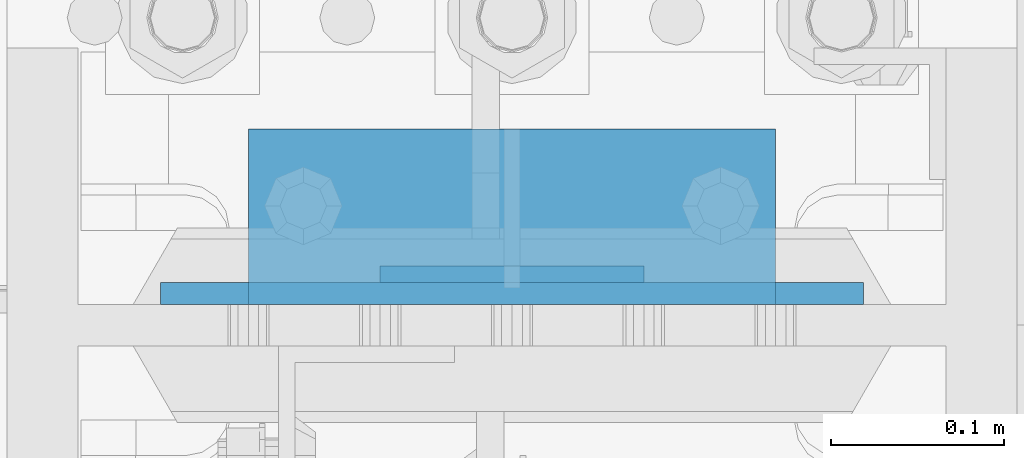
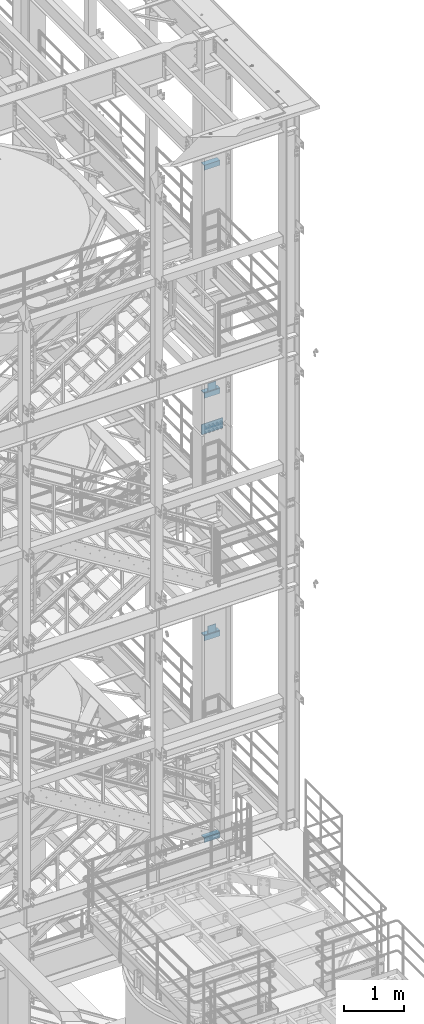
# One storey, part 1220 of 1876: 9 beams, 4 elements without a shape of their own.
"""IFC2X3 building model written with IfcOpenShell, lengths in millimetres."""

from ifc_helpers import new_model, si_unit, frame, origin_with_axes, place, context, subcontext, project, spatial, faceted_brep, material, type_object, element, aggregate, save


model = new_model("IFC2X3")

# Units and contexts
model_context = context("Model", 3, precision=1e-05, world=origin_with_axes())
body_context = subcontext(model_context, "Body", "Model", "MODEL_VIEW")
ifc_project = project(units=[si_unit("LENGTHUNIT", "METRE", prefix="MILLI"), si_unit("AREAUNIT", "SQUARE_METRE"), si_unit("VOLUMEUNIT", "CUBIC_METRE"), si_unit("MASSUNIT", "GRAM", prefix="KILO"), si_unit("TIMEUNIT", "SECOND"), si_unit("PLANEANGLEUNIT", "RADIAN"), si_unit("SOLIDANGLEUNIT", "STERADIAN"), si_unit("THERMODYNAMICTEMPERATUREUNIT", "DEGREE_CELSIUS"), si_unit("LUMINOUSINTENSITYUNIT", "LUMEN")], contexts=[model_context])

# Site, building, storey
site_placement = place(None, origin_with_axes())
site = spatial("IfcSite", under=ifc_project, at=site_placement, CompositionType="ELEMENT")
building_placement = place(site_placement, origin_with_axes())
building = spatial("IfcBuilding", under=site, at=building_placement, Name="Undefined", CompositionType="ELEMENT")
storey_placement = place(building_placement, origin_with_axes())
storey = spatial("IfcBuildingStorey", under=building, at=storey_placement, Name="Undefined", CompositionType="ELEMENT", Elevation=0.0)

# Assembly, beam
assembly_1_placement = place(storey_placement, origin_with_axes())
assembly_1 = element("IfcElementAssembly", 1, at=assembly_1_placement, inside=storey, Name="BEAM", AssemblyPlace="NOTDEFINED", PredefinedType="RIGID_FRAME")
ifc_material_1 = material(Name="STEEL/A36")
beam_type_1 = type_object("IfcBeamType", PredefinedType="NOTDEFINED")
beam_1_placement = place(assembly_1_placement, frame((7696.2, -4542.63125, 15335.25), z_axis=(0.0, 0.0, 1.0), x_axis=(-1.0, 0.0, 0.0)))
beam_1 = element("IfcBeam", 2, at=beam_1_placement, type_object=beam_type_1, material=ifc_material_1, Name="PLATE", context=body_context, shape_type="Brep", body=[
    faceted_brep([(0.0, 4.76249999999982, -76.1999999999998), (3.63797880709171e-12, 4.76249999999982, 76.1999969482422), (152.399993896484, 4.76250000000073, 76.1999969482422), (152.4, 4.76249999999982, -76.1999999999998), (3.63797880709171e-12, -4.76249999999982, 76.1999969482422), (152.399993896484, -4.76250000000073, 76.1999969482422), (0.0, -4.76249999999982, -76.1999999999998), (152.4, -4.76249999999982, -76.1999999999998)], [[[0, 1, 2, 3]], [[4, 5, 2, 1]], [[4, 6, 7, 5]], [[6, 0, 3, 7]], [[5, 7, 3, 2]], [[6, 4, 1, 0]]]),
])

assembly_2_placement = place(storey_placement, origin_with_axes())
assembly_2 = element("IfcElementAssembly", 3, at=assembly_2_placement, inside=storey, Name="BEAM", AssemblyPlace="NOTDEFINED", PredefinedType="RIGID_FRAME")
beam_2_placement = place(assembly_2_placement, frame((7696.2, -4542.63125, 10420.35), z_axis=(0.0, 0.0, 1.0), x_axis=(-1.0, 0.0, 0.0)))
beam_2 = element("IfcBeam", 4, at=beam_2_placement, type_object=beam_type_1, material=ifc_material_1, Name="PLATE", context=body_context, shape_type="Brep", body=[
    faceted_brep([(0.0, 4.76249999999982, -76.1999999999998), (3.63797880709171e-12, 4.76249999999982, 76.1999969482422), (152.399993896484, 4.76250000000073, 76.1999969482422), (152.4, 4.76249999999982, -76.1999999999998), (3.63797880709171e-12, -4.76249999999982, 76.1999969482422), (152.399993896484, -4.76250000000073, 76.1999969482422), (0.0, -4.76249999999982, -76.1999999999998), (152.4, -4.76249999999982, -76.1999999999998)], [[[0, 1, 2, 3]], [[4, 5, 2, 1]], [[4, 6, 7, 5]], [[6, 0, 3, 7]], [[5, 7, 3, 2]], [[6, 4, 1, 0]]]),
])

# Beam
beam_type_2 = type_object("IfcBeamType", PredefinedType="NOTDEFINED")
beam_3_placement = place(assembly_1_placement, frame((7467.6, -4502.94375, 15254.2875), z_axis=(0.0, 1.0, 0.0), x_axis=(1.0, 0.0, 0.0)))
beam_3 = element("IfcBeam", 5, at=beam_3_placement, type_object=beam_type_2, material=ifc_material_1, Name="PLATE", context=body_context, shape_type="Brep", body=[
    faceted_brep([(0.0, 4.76250000000073, -44.4499999999998), (0.0, 4.76250000000073, 44.4499999999998), (304.799999999999, 4.76250000000073, 44.4499999999998), (304.799999999999, 4.76250000000073, -44.4499999999998), (0.0, -4.76250000000073, 44.4499999999998), (304.799999999999, -4.76250000000073, 44.4499999999998), (0.0, -4.76250000000073, -44.4499999999998), (304.799999999999, -4.76250000000073, -44.4499999999998)], [[[0, 1, 2, 3]], [[1, 4, 5, 2]], [[4, 6, 7, 5]], [[6, 0, 3, 7]], [[5, 7, 3, 2]], [[6, 4, 1, 0]]]),
])

aggregate(assembly_1, [beam_1, beam_3])

beam_4_placement = place(assembly_2_placement, frame((7467.6, -4502.94375, 10339.3875), z_axis=(0.0, 1.0, 0.0), x_axis=(1.0, 0.0, 0.0)))
beam_4 = element("IfcBeam", 6, at=beam_4_placement, type_object=beam_type_2, material=ifc_material_1, Name="PLATE", context=body_context, shape_type="Brep", body=[
    faceted_brep([(0.0, 4.76250000000073, -44.4499999999998), (0.0, 4.76250000000073, 44.4499999999998), (304.799999999999, 4.76250000000073, 44.4499999999998), (304.799999999999, 4.76250000000073, -44.4499999999998), (0.0, -4.76250000000073, 44.4499999999998), (304.799999999999, -4.76250000000073, 44.4499999999998), (0.0, -4.76250000000073, -44.4499999999998), (304.799999999999, -4.76250000000073, -44.4499999999998)], [[[0, 1, 2, 3]], [[1, 4, 5, 2]], [[4, 6, 7, 5]], [[6, 0, 3, 7]], [[5, 7, 3, 2]], [[6, 4, 1, 0]]]),
])

aggregate(assembly_2, [beam_2, beam_4])

# Assembly, beams
assembly_3_placement = place(storey_placement, origin_with_axes())
assembly_3 = element("IfcElementAssembly", 7, at=assembly_3_placement, inside=storey, Name="COLUMN", AssemblyPlace="NOTDEFINED", PredefinedType="RIGID_FRAME")
beam_type_3 = type_object("IfcBeamType", Name="L4X4X3/8", PredefinedType="NOTDEFINED")
beam_5_placement = place(assembly_3_placement, frame((7772.4, -4509.29375, 19821.525), z_axis=(0.0, 1.0, 0.0), x_axis=(-1.0, 0.0, 0.0)))
beam_5 = element("IfcBeam", 8, at=beam_5_placement, type_object=beam_type_3, material=ifc_material_1, Name="ANGLE", ObjectType="L4X4X3/8", context=body_context, shape_type="Brep", body=[
    faceted_brep([(0.0, 50.7999999999993, -50.8000000000002), (0.0, 50.7999999999993, 50.8000000000002), (304.799999999999, 50.7999999999993, 50.8000000000002), (304.799999999999, 50.7999999999993, -50.8000000000002), (0.0, 41.2750000000015, 50.8000000000002), (304.799999999999, 41.2750000000015, 50.8000000000002), (0.0, 41.2750000000015, -41.2749999999996), (304.799999999999, 41.2750000000015, -41.2749999999996), (0.0, -50.7999999999993, -41.2749999999996), (304.799999999999, -50.7999999999993, -41.2749999999996), (0.0, -50.7999999999993, -50.8000000000002), (304.799999999999, -50.7999999999993, -50.8000000000002)], [[[0, 1, 2, 3]], [[1, 4, 5, 2]], [[4, 6, 7, 5]], [[6, 8, 9, 7]], [[8, 10, 11, 9]], [[10, 0, 3, 11]], [[5, 7, 9, 11, 3, 2]], [[10, 8, 6, 4, 1, 0]]]),
])
beam_6_placement = place(assembly_3_placement, frame((7772.4, -4509.29375, 15198.725), z_axis=(0.0, 1.0, 0.0), x_axis=(-1.0, 0.0, 0.0)))
beam_6 = element("IfcBeam", 9, at=beam_6_placement, type_object=beam_type_3, material=ifc_material_1, Name="ANGLE", ObjectType="L4X4X3/8", context=body_context, shape_type="Brep", body=[
    faceted_brep([(0.0, 50.7999999999993, -50.8000000000002), (0.0, 50.7999999999993, 50.8000000000002), (304.799999999999, 50.7999999999993, 50.8000000000002), (304.799999999999, 50.7999999999993, -50.8000000000002), (0.0, 41.2750000000015, 50.8000000000002), (304.799999999999, 41.2750000000015, 50.8000000000002), (0.0, 41.2750000000015, -41.2749999999996), (304.799999999999, 41.2750000000015, -41.2749999999996), (0.0, -50.7999999999993, -41.2749999999996), (304.799999999999, -50.7999999999993, -41.2749999999996), (0.0, -50.7999999999993, -50.8000000000002), (304.799999999999, -50.7999999999993, -50.8000000000002)], [[[0, 1, 2, 3]], [[1, 4, 5, 2]], [[4, 6, 7, 5]], [[6, 8, 9, 7]], [[8, 10, 11, 9]], [[10, 0, 3, 11]], [[5, 7, 9, 11, 3, 2]], [[10, 8, 6, 4, 1, 0]]]),
])
aggregate(assembly_3, [beam_5, beam_6])

assembly_4_placement = place(storey_placement, origin_with_axes())
assembly_4 = element("IfcElementAssembly", 10, at=assembly_4_placement, inside=storey, Name="COLUMN", AssemblyPlace="NOTDEFINED", PredefinedType="RIGID_FRAME")
beam_7_placement = place(assembly_4_placement, frame((7772.4, -4509.29375, 10283.825), z_axis=(0.0, 1.0, 0.0), x_axis=(-1.0, 0.0, 0.0)))
beam_7 = element("IfcBeam", 11, at=beam_7_placement, type_object=beam_type_3, material=ifc_material_1, Name="ANGLE", ObjectType="L4X4X3/8", context=body_context, shape_type="Brep", body=[
    faceted_brep([(0.0, 50.7999999999993, -50.8000000000002), (0.0, 50.7999999999993, 50.8000000000002), (304.799999999999, 50.7999999999993, 50.8000000000002), (304.799999999999, 50.7999999999993, -50.8000000000002), (0.0, 41.2750000000015, 50.8000000000002), (304.799999999999, 41.2750000000015, 50.8000000000002), (0.0, 41.2750000000015, -41.2749999999996), (304.799999999999, 41.2750000000015, -41.2749999999996), (0.0, -50.7999999999993, -41.2749999999996), (304.799999999999, -50.7999999999993, -41.2749999999996), (0.0, -50.7999999999993, -50.8000000000002), (304.799999999999, -50.7999999999993, -50.8000000000002)], [[[0, 1, 2, 3]], [[1, 4, 5, 2]], [[4, 6, 7, 5]], [[6, 8, 9, 7]], [[8, 10, 11, 9]], [[10, 0, 3, 11]], [[5, 7, 9, 11, 3, 2]], [[10, 8, 6, 4, 1, 0]]]),
])
beam_8_placement = place(assembly_4_placement, frame((7772.4, -4509.29375, 6194.425), z_axis=(0.0, 1.0, 0.0), x_axis=(-1.0, 0.0, 0.0)))
beam_8 = element("IfcBeam", 12, at=beam_8_placement, type_object=beam_type_3, material=ifc_material_1, Name="ANGLE", ObjectType="L4X4X3/8", context=body_context, shape_type="Brep", body=[
    faceted_brep([(0.0, 50.7999999999993, -50.8000000000002), (0.0, 50.7999999999993, 50.8000000000002), (304.799999999999, 50.7999999999993, 50.8000000000002), (304.799999999999, 50.7999999999993, -50.8000000000002), (0.0, 41.2750000000015, 50.8000000000002), (304.799999999999, 41.2750000000015, 50.8000000000002), (0.0, 41.2750000000015, -41.2749999999996), (304.799999999999, 41.2750000000015, -41.2749999999996), (0.0, -50.7999999999993, -41.2749999999996), (304.799999999999, -50.7999999999993, -41.2749999999996), (0.0, -50.7999999999993, -50.8000000000002), (304.799999999999, -50.7999999999993, -50.8000000000002)], [[[0, 1, 2, 3]], [[1, 4, 5, 2]], [[4, 6, 7, 5]], [[6, 8, 9, 7]], [[8, 10, 11, 9]], [[10, 0, 3, 11]], [[5, 7, 9, 11, 3, 2]], [[10, 8, 6, 4, 1, 0]]]),
])
ifc_material_2 = material(Name="STEEL/A572-50")
beam_type_4 = type_object("IfcBeamType", PredefinedType="NOTDEFINED")
beam_9_placement = place(assembly_4_placement, frame((7620.0, -4553.74375, 14636.75), z_axis=(-1.0, 0.0, 0.0), x_axis=(0.0, 0.0, -1.0)))
beam_9 = element("IfcBeam", 13, at=beam_9_placement, type_object=beam_type_4, material=ifc_material_2, Name="PLATE", context=body_context, shape_type="Brep", body=[
    faceted_brep([(0.0, 6.35000000000036, -203.2), (0.0, 6.35000000000036, 203.2), (209.550000000001, 6.35000000000036, 203.2), (209.550000000001, 6.35000000000036, -203.2), (0.0, -6.35000000000036, 203.2), (209.550000000001, -6.35000000000036, 203.2), (0.0, -6.35000000000036, -203.2), (209.550000000001, -6.35000000000036, -203.2)], [[[0, 1, 2, 3]], [[1, 4, 5, 2]], [[4, 6, 7, 5]], [[6, 0, 3, 7]], [[5, 7, 3, 2]], [[6, 4, 1, 0]]]),
])
aggregate(assembly_4, [beam_7, beam_8, beam_9])

save(model, "model.ifc")
